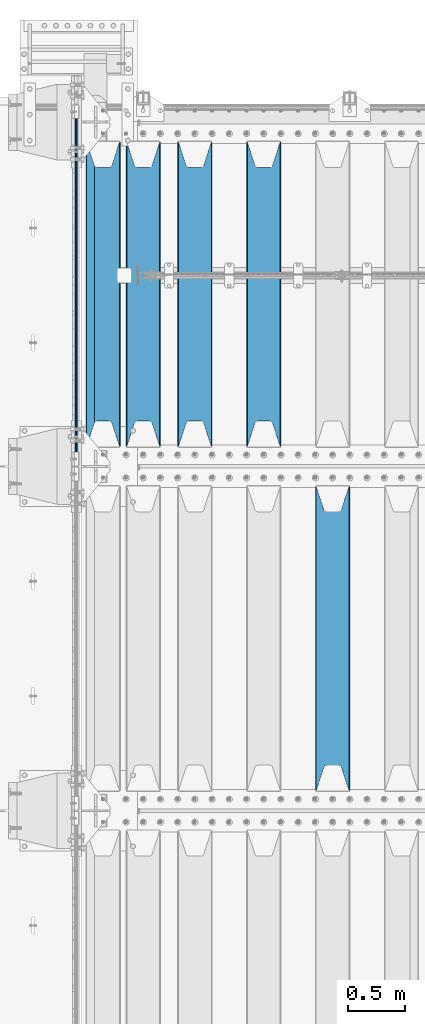
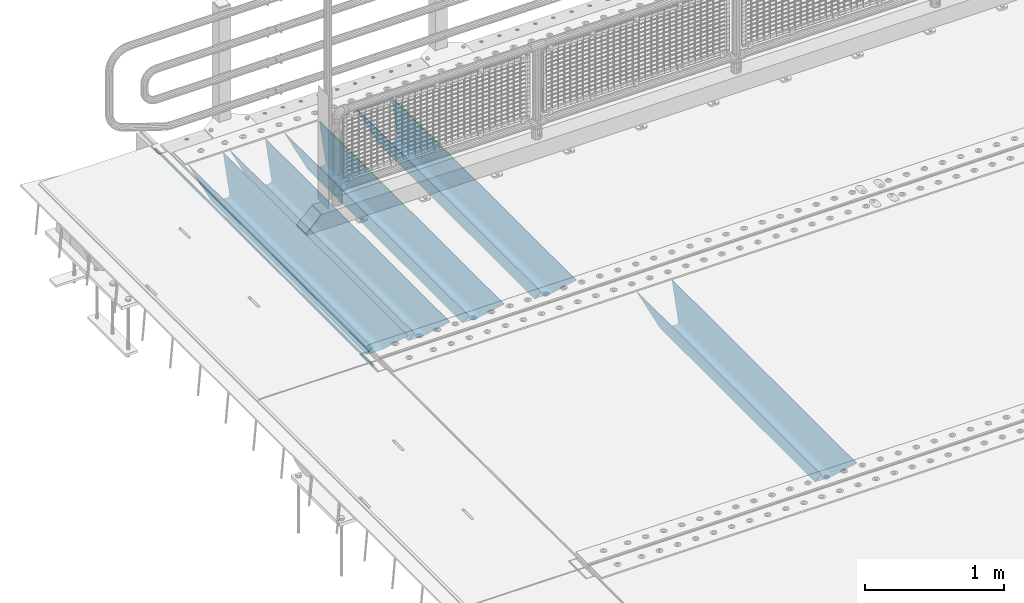
# One storey, part 113 of 240: 6 beams.
"""IFC2X3 building model written with IfcOpenShell, lengths in millimetres."""

import ifcopenshell
import ifcopenshell.guid

model = None  # the IFC model being written
_history = None  # IfcOwnerHistory: only IFC2X3 demands one
_inside = {}  # id of a spatial element -> (the spatial element, [elements in it])
_under = {}  # id of a project, library or spatial element -> (it, [spatial elements below it])
_declared = {}  # id of a project -> (the project, [libraries it declares])
_typed = {}  # id of a type object -> (the type object, [elements of that type])
_made_of = {}  # id of a material, layer set ... -> (it, [elements and type objects made of it])


def new_model(schema):
    """Start an empty IFC model of exactly this schema.

    Asked for "IFC4X3", IfcOpenShell would pick the latest addendum, in which some entities
    have other attributes; the version numbers below select the first issue.
    IFC2X3 requires an IfcOwnerHistory on every rooted entity: one is made here for all.
    """
    global model, _history
    if schema == "IFC4X3":
        model = ifcopenshell.file(schema_version=(4, 3, 0, 0))
    else:
        model = ifcopenshell.file(schema=schema)
    _inside.clear()
    _under.clear()
    _declared.clear()
    _typed.clear()
    _made_of.clear()
    _history = None
    if model.schema == "IFC2X3":
        org = make("IfcOrganization", Name="unknown")
        user = make(
            "IfcPersonAndOrganization",
            ThePerson=make("IfcPerson", FamilyName="unknown"),
            TheOrganization=org,
        )
        app = make(
            "IfcApplication",
            ApplicationDeveloper=org,
            Version="unknown",
            ApplicationFullName="unknown",
            ApplicationIdentifier="unknown",
        )
        _history = make(
            "IfcOwnerHistory",
            OwningUser=user,
            OwningApplication=app,
            ChangeAction="ADDED",
            CreationDate=0,
        )
    return model


def make(cls, **values):
    """One entity of the class cls with the attributes given. An attribute that is None is left unset."""
    return model.create_entity(
        cls, **{name: value for name, value in values.items() if value is not None}
    )


def rooted(cls, **values):
    """An entity with a GlobalId (a new one), such as an element, a storey or a relation."""
    return make(cls, GlobalId=ifcopenshell.guid.new(), OwnerHistory=_history, **values)


def si_unit(unit_type, name, prefix=None):
    """IfcSIUnit, for example si_unit("LENGTHUNIT", "METRE", prefix="MILLI")."""
    return make("IfcSIUnit", UnitType=unit_type, Prefix=prefix, Name=name)


def assignment(units):
    """IfcUnitAssignment: the units of a project."""
    return None if units is None else make("IfcUnitAssignment", Units=units)


def point(xyz):
    """IfcCartesianPoint."""
    return None if xyz is None else make("IfcCartesianPoint", Coordinates=xyz)


def direction(xyz):
    """IfcDirection."""
    return None if xyz is None else make("IfcDirection", DirectionRatios=xyz)


def frame(location, z_axis=None, x_axis=None):
    """IfcAxis2Placement3D, a coordinate frame: its origin and axes. An axis left out is left unset."""
    return make(
        "IfcAxis2Placement3D",
        Location=point(location),
        Axis=direction(z_axis),
        RefDirection=direction(x_axis),
    )


def origin_with_axes():
    """The frame at (0, 0, 0) with the z axis (0, 0, 1) and the x axis (1, 0, 0) written out."""
    return frame((0.0, 0.0, 0.0), z_axis=(0.0, 0.0, 1.0), x_axis=(1.0, 0.0, 0.0))


def place(relative_to, where):
    """IfcLocalPlacement: puts the frame where relative to a parent placement (None: the world)."""
    return make(
        "IfcLocalPlacement", PlacementRelTo=relative_to, RelativePlacement=where
    )


def context(
    kind, dimensions, precision=None, world=None, true_north=None, identifier=None
):
    """IfcGeometricRepresentationContext, for example the 3D "Model" context."""
    return make(
        "IfcGeometricRepresentationContext",
        ContextIdentifier=identifier,
        ContextType=kind,
        CoordinateSpaceDimension=dimensions,
        Precision=precision,
        WorldCoordinateSystem=world,
        TrueNorth=true_north,
    )


def subcontext(parent, identifier, kind, view, scale=None):
    """IfcGeometricRepresentationSubContext, for example "Body" below "Model"."""
    return make(
        "IfcGeometricRepresentationSubContext",
        ContextIdentifier=identifier,
        ContextType=kind,
        ParentContext=parent,
        TargetScale=scale,
        TargetView=view,
    )


def project(units=None, contexts=None):
    """IfcProject with its units and contexts."""
    return rooted(
        "IfcProject",
        Name="project",
        RepresentationContexts=contexts,
        UnitsInContext=assignment(units),
    )


def spatial(cls, under=None, at=None, **own):
    """A site, building, storey or space (cls), placed at a placement, below another one or the project."""
    s = rooted(cls, ObjectPlacement=at, **own)
    if under is not None:
        _under.setdefault(under.id(), (under, []))[1].append(s)
    return s


def faces_of(points, faces, orient=None, outer=None):
    """IfcFace entities. A face is a list of loops; a loop is a list of indices into points, from 0.

    orient and outer hold one flag for each loop. By default every Orientation is true, the
    first loop of a face is its IfcFaceOuterBound and the others are IfcFaceBound.
    """
    made = []
    for i, loops in enumerate(faces):
        bounds = []
        for j, loop in enumerate(loops):
            is_outer = j == 0 if outer is None else outer[i][j]
            bounds.append(
                make(
                    "IfcFaceOuterBound" if is_outer else "IfcFaceBound",
                    Bound=make("IfcPolyLoop", Polygon=[points[k] for k in loop]),
                    Orientation=True if orient is None else orient[i][j],
                )
            )
        made.append(make("IfcFace", Bounds=bounds))
    return made


def faceted_brep(points, faces, orient=None, outer=None, voids=None):
    """IfcFacetedBrep: a solid bounded by flat faces; with voids (closed shells), ...WithVoids."""
    shared = [point(p) for p in points]
    hull = make("IfcClosedShell", CfsFaces=faces_of(shared, faces, orient, outer))
    if voids is None:
        return make("IfcFacetedBrep", Outer=hull)
    return make(
        "IfcFacetedBrepWithVoids",
        Outer=hull,
        Voids=[
            make(cls, CfsFaces=faces_of(shared, fs, o, b)) for cls, fs, o, b in voids
        ],
    )


def shape(context_of_items, identifier, shape_type, items):
    """IfcShapeRepresentation: the items that make up one representation, for example the "Body"."""
    return make(
        "IfcShapeRepresentation",
        ContextOfItems=context_of_items,
        RepresentationIdentifier=identifier,
        RepresentationType=shape_type,
        Items=items,
    )


def material(Name=None, Category=None):
    """IfcMaterial."""
    return make("IfcMaterial", Name=Name, Category=Category)


def made_of(thing, what):
    """Note that an element or type object is made of a material, layer set ...; save() writes the relation."""
    if what is not None:
        _made_of.setdefault(what.id(), (what, []))[1].append(thing)
    return thing


def type_object(cls, material=None, **own):
    """A type object (cls), such as IfcWallType, which elements share."""
    return made_of(rooted(cls, **own), material)


def element(
    cls,
    number,
    at=None,
    inside=None,
    cuts=None,
    type_object=None,
    material=None,
    context=None,
    identifier="Body",
    shape_type=None,
    held_by="IfcProductDefinitionShape",
    body=None,
    shapes=None,
    **own,
):
    """One element of the class cls, such as IfcWall. Its Tag is "e" and its number.

    at: its placement. inside: the storey or other place that contains it. cuts: it is an
    opening in that element (IfcRelVoidsElement). A single representation is given by context,
    identifier, shape_type and body (its items); several are given by shapes. held_by: the class
    of the entity that holds the representations. save() writes the other relations.
    """
    e = rooted(cls, Tag="e%d" % number, ObjectPlacement=at, **own)
    if body is not None:
        shapes = [shape(context, identifier, shape_type, body)]
    if shapes is not None:
        e.Representation = make(held_by, Representations=shapes)
    if inside is not None:
        _inside.setdefault(inside.id(), (inside, []))[1].append(e)
    if cuts is not None:
        rooted(
            "IfcRelVoidsElement", RelatingBuildingElement=cuts, RelatedOpeningElement=e
        )
    if type_object is not None:
        _typed.setdefault(type_object.id(), (type_object, []))[1].append(e)
    return made_of(e, material)


def aggregate(whole, parts):
    """IfcRelAggregates: a whole, such as a stair, and the parts it consists of."""
    return rooted("IfcRelAggregates", RelatingObject=whole, RelatedObjects=parts)


def save(model, path):
    """Write the relations noted so far, then the file.

    IfcRelAggregates (storeys below a building ...), IfcRelContainedInSpatialStructure (elements
    in a storey), IfcRelDefinesByType, IfcRelAssociatesMaterial and IfcRelDeclares: one each for
    every whole, place, type object, material and project.
    """
    for whole, parts in _under.values():
        aggregate(whole, parts)
    for where, things in _inside.values():
        rooted(
            "IfcRelContainedInSpatialStructure",
            RelatedElements=things,
            RelatingStructure=where,
        )
    for kind, things in _typed.values():
        rooted("IfcRelDefinesByType", RelatedObjects=things, RelatingType=kind)
    for what, things in _made_of.values():
        rooted("IfcRelAssociatesMaterial", RelatedObjects=things, RelatingMaterial=what)
    for by, libraries in _declared.values():
        rooted("IfcRelDeclares", RelatingContext=by, RelatedDefinitions=libraries)
    model.write(path)


model = new_model("IFC2X3")

# Units and contexts
model_context = context("Model", 3, precision=1e-05, world=origin_with_axes())
body_context = subcontext(model_context, "Body", "Model", "MODEL_VIEW")
ifc_project = project(units=[si_unit("LENGTHUNIT", "METRE", prefix="MILLI"), si_unit("AREAUNIT", "SQUARE_METRE"), si_unit("VOLUMEUNIT", "CUBIC_METRE"), si_unit("MASSUNIT", "GRAM", prefix="KILO"), si_unit("TIMEUNIT", "SECOND"), si_unit("PLANEANGLEUNIT", "RADIAN"), si_unit("SOLIDANGLEUNIT", "STERADIAN"), si_unit("THERMODYNAMICTEMPERATUREUNIT", "DEGREE_CELSIUS"), si_unit("LUMINOUSINTENSITYUNIT", "LUMEN")], contexts=[model_context])

# Site, building, storey
site_placement = place(None, origin_with_axes())
site = spatial("IfcSite", under=ifc_project, at=site_placement, CompositionType="ELEMENT")
building_placement = place(site_placement, origin_with_axes())
building = spatial("IfcBuilding", under=site, at=building_placement, Name="Standard", CompositionType="ELEMENT")
storey_placement = place(building_placement, origin_with_axes())
storey = spatial("IfcBuildingStorey", under=building, at=storey_placement, Name="Undefined", CompositionType="ELEMENT", Elevation=0.0)

# Beams
ifc_material = material(Name="STEEL/S355N")
beam_type_1 = type_object("IfcBeamType", Name="D20", PredefinedType="NOTDEFINED")
beam_1_placement = place(storey_placement, frame((42415.0, 33004.9999999999, -25.9999999971316), z_axis=(0.0, 0.0, 1.0), x_axis=(0.0, 1.0, 0.0)))
element("IfcBeam", 1, at=beam_1_placement, inside=storey, type_object=beam_type_1, material=ifc_material, ObjectType="D20", context=body_context, shape_type="Brep", body=[
    faceted_brep([(0.0, -10.0, 0.0), (0.0, -7.07106781186303, -7.07106781186548), (3144.99999999996, -7.07106781186303, -7.07106781186548), (3144.99999999996, -10.0, 0.0), (0.0, 0.0, -10.0), (3144.99999999996, 0.0, -10.0), (0.0, 7.07106781186303, -7.07106781186547), (3144.99999999996, 7.07106781186303, -7.07106781186547), (0.0, 10.0, 0.0), (3144.99999999996, 10.0, 0.0), (0.0, 7.07106781186303, 7.07106781186548), (3144.99999999996, 7.07106781186303, 7.07106781186548), (0.0, 0.0, 10.0), (3144.99999999996, 0.0, 10.0), (0.0, -7.07106781186303, 7.07106781186548), (3144.99999999996, -7.07106781186303, 7.07106781186548)], [[[0, 1, 2, 3]], [[1, 4, 5, 2]], [[4, 6, 7, 5]], [[6, 8, 9, 7]], [[8, 10, 11, 9]], [[10, 12, 13, 11]], [[12, 14, 15, 13]], [[14, 0, 3, 15]], [[5, 7, 9, 11, 13, 15, 3, 2]], [[14, 12, 10, 8, 6, 4, 1, 0]]]),
])
beam_type_2 = type_object("IfcBeamType", PredefinedType="NOTDEFINED")
beam_2_placement = place(storey_placement, frame((44650.0, 30175.0, -115.0), z_axis=(0.0, 0.0, 1.0), x_axis=(0.0, 1.0, 0.0)))
element("IfcBeam", 2, at=beam_2_placement, inside=storey, type_object=beam_type_2, material=ifc_material, context=body_context, shape_type="Brep", body=[
    faceted_brep([(0.0, 150.0, 115.0), (0.0, 143.690000000002, 115.0), (2650.00000000297, 143.690000000002, 115.0), (2650.00000000297, 150.0, 115.0), (2650.00000000297, 142.059565218406, 110.000000003094), (2650.00000000297, 148.369565218403, 110.000000003094), (2441.90079219209, -80.1103600731149, -98.0992078077845), (2437.7588105432, -77.5672621345584, -102.241189456673), (2434.06523489747, -74.4080125315522, -105.934765102404), (2430.9108609509, -70.7102721255724, -109.089139048974), (2428.37322971128, -66.5649389910031, -111.626770288588), (2426.51472138055, -62.0739139532889, -113.485278619323), (2425.38102192092, -57.3475956567636, -114.618978078955), (2424.99999999987, -52.5021667386536, -115.0), (2424.99999999987, 52.5021667386536, -115.0), (2425.38102192092, 57.3475956567636, -114.618978078955), (2426.51472138055, 62.0739139532889, -113.485278619323), (2428.37322971128, 66.5649389910031, -111.626770288588), (2430.9108609509, 70.7102721255724, -109.089139048974), (2434.06523489747, 74.4080125315522, -105.934765102404), (2437.7588105432, 77.5672621345584, -102.241189456673), (2441.90079219209, 80.1103600731149, -98.0992078077846), (2446.38936140512, 81.9747917625791, -93.6106385947584), (2448.2494850041, 76.2713538057287, -91.7505149957729), (2444.62967112263, 74.76777986261, -95.3703288772456), (2441.28936334127, 72.7168944282894, -98.710636658607), (2438.31067330439, 70.1691124903809, -101.689326695487), (2435.76682334748, 67.1870637758839, -104.233176652398), (2433.72034654134, 63.8440531834931, -106.279653458539), (2432.22154950042, 60.2222587982324, -107.778450499454), (2431.30727574265, 56.4107117849126, -108.692724257221), (2430.99999999987, 52.5031078186876, -109.0), (2430.99999999987, -52.5031078186876, -109.0), (2431.30727574265, -56.4107117849126, -108.692724257221), (2432.22154950042, -60.2222587982324, -107.778450499454), (2433.72034654134, -63.8440531834931, -106.279653458539), (2435.76682334748, -67.1870637758839, -104.233176652398), (2438.31067330439, -70.1691124903809, -101.689326695487), (2441.28936334127, -72.7168944282894, -98.7106366586071), (2444.62967112263, -74.76777986261, -95.3703288772457), (2448.2494850041, -76.2713538057287, -91.7505149957729), (2650.00000000297, -142.059565218406, 110.000000003094), (2650.00000000297, -148.369565218403, 110.000000003094), (2446.38936140512, -81.9747917625791, -93.6106385947584), (2650.00000000297, -143.690000000002, 115.0), (2650.00000000297, -150.0, 115.0), (0.0, -143.690000000002, 115.0), (0.0, -150.0, 115.0), (0.0, -148.369565218258, 110.000000002667), (203.610638597427, -81.9747917625791, -93.6106385947584), (208.09920781045, -80.1103600731149, -98.0992078077845), (212.241189459342, -77.5672621345584, -102.241189456673), (215.93476510507, -74.4080125315522, -105.934765102404), (219.089139051641, -70.7102721255724, -109.089139048974), (221.626770291256, -66.5649389910031, -111.626770288588), (223.485278621989, -62.0739139532889, -113.485278619323), (224.618978081624, -57.3475956567636, -114.618978078955), (225.000000002663, -52.5021667386536, -115.0), (225.000000002663, 52.5021667386536, -115.0), (224.618978081624, 57.3475956567636, -114.618978078955), (223.485278621989, 62.0739139532889, -113.485278619323), (221.626770291256, 66.5649389910031, -111.626770288588), (219.089139051641, 70.7102721255724, -109.089139048974), (215.93476510507, 74.4080125315522, -105.934765102404), (212.241189459342, 77.5672621345584, -102.241189456673), (208.09920781045, 80.1103600731149, -98.0992078077846), (203.610638597427, 81.9747917625791, -93.6106385947584), (0.0, 148.369565218258, 110.000000002667), (0.0, 142.05956521826, 110.000000002667), (201.750514998439, 76.2713538057287, -91.7505149957729), (205.370328879908, 74.76777986261, -95.3703288772456), (208.710636661275, 72.7168944282894, -98.710636658607), (211.689326698153, 70.1691124903809, -101.689326695487), (214.233176655063, 67.1870637758839, -104.233176652398), (216.279653461206, 63.8440531834931, -106.279653458539), (217.778450502123, 60.2222587982324, -107.778450499454), (218.692724259887, 56.4107117849126, -108.692724257221), (219.000000002667, 52.5031078186876, -109.0), (219.000000002667, -52.5031078186876, -109.0), (218.692724259887, -56.4107117849126, -108.692724257221), (217.778450502123, -60.2222587982324, -107.778450499454), (216.279653461206, -63.8440531834931, -106.279653458539), (214.233176655063, -67.1870637758839, -104.233176652398), (211.689326698153, -70.1691124903809, -101.689326695487), (208.710636661275, -72.7168944282894, -98.7106366586071), (205.370328879915, -74.76777986261, -95.3703288772457), (201.750514998439, -76.2713538057287, -91.7505149957729), (0.0, -142.05956521826, 110.000000002667)], [[[0, 1, 2, 3]], [[3, 2, 4, 5]], [[6, 7, 8, 9, 10, 11, 12, 13, 14, 15, 16, 17, 18, 19, 20, 21, 22, 5, 4, 23, 24, 25, 26, 27, 28, 29, 30, 31, 32, 33, 34, 35, 36, 37, 38, 39, 40, 41, 42, 43]], [[44, 45, 42, 41]], [[46, 47, 45, 44]], [[43, 42, 45, 47, 48, 49]], [[6, 43, 49, 50]], [[7, 6, 50, 51]], [[8, 7, 51, 52]], [[9, 8, 52, 53]], [[10, 9, 53, 54]], [[11, 10, 54, 55]], [[12, 11, 55, 56]], [[13, 12, 56, 57]], [[14, 13, 57, 58]], [[15, 14, 58, 59]], [[16, 15, 59, 60]], [[17, 16, 60, 61]], [[18, 17, 61, 62]], [[19, 18, 62, 63]], [[20, 19, 63, 64]], [[21, 20, 64, 65]], [[22, 21, 65, 66]], [[0, 3, 5, 22, 66, 67]], [[1, 0, 67, 68]], [[23, 4, 2, 1, 68, 69]], [[24, 23, 69, 70]], [[25, 24, 70, 71]], [[26, 25, 71, 72]], [[27, 26, 72, 73]], [[28, 27, 73, 74]], [[29, 28, 74, 75]], [[30, 29, 75, 76]], [[31, 30, 76, 77]], [[32, 31, 77, 78]], [[33, 32, 78, 79]], [[34, 33, 79, 80]], [[35, 34, 80, 81]], [[36, 35, 81, 82]], [[37, 36, 82, 83]], [[38, 37, 83, 84]], [[39, 38, 84, 85]], [[40, 39, 85, 86]], [[46, 44, 41, 40, 86, 87]], [[47, 46, 87, 48]], [[86, 85, 84, 83, 82, 81, 80, 79, 78, 77, 76, 75, 74, 73, 72, 71, 70, 69, 68, 67, 66, 65, 64, 63, 62, 61, 60, 59, 58, 57, 56, 55, 54, 53, 52, 51, 50, 49, 48, 87]]]),
])
beam_3_placement = place(storey_placement, frame((44050.0, 33175.0, -115.0), z_axis=(0.0, 0.0, 1.0), x_axis=(0.0, 1.0, 0.0)))
element("IfcBeam", 3, at=beam_3_placement, inside=storey, type_object=beam_type_2, material=ifc_material, context=body_context, shape_type="Brep", body=[
    faceted_brep([(0.0, 150.0, 115.0), (0.0, 143.690000000002, 115.0), (2650.00000000297, 143.690000000002, 115.0), (2650.00000000297, 150.0, 115.0), (2650.00000000297, 142.059565218406, 110.000000003094), (2650.00000000297, 148.369565218403, 110.000000003094), (2441.90079219209, -80.1103600731149, -98.0992078077845), (2437.7588105432, -77.5672621345584, -102.241189456673), (2434.06523489747, -74.4080125315522, -105.934765102404), (2430.9108609509, -70.7102721255724, -109.089139048974), (2428.37322971128, -66.5649389910031, -111.626770288588), (2426.51472138055, -62.0739139532889, -113.485278619323), (2425.38102192092, -57.3475956567636, -114.618978078955), (2424.99999999987, -52.5021667386536, -115.0), (2424.99999999987, 52.5021667386536, -115.0), (2425.38102192092, 57.3475956567636, -114.618978078955), (2426.51472138055, 62.0739139532889, -113.485278619323), (2428.37322971128, 66.5649389910031, -111.626770288588), (2430.9108609509, 70.7102721255724, -109.089139048974), (2434.06523489747, 74.4080125315522, -105.934765102404), (2437.7588105432, 77.5672621345584, -102.241189456673), (2441.90079219209, 80.1103600731149, -98.0992078077846), (2446.38936140512, 81.9747917625791, -93.6106385947584), (2448.2494850041, 76.2713538057287, -91.7505149957729), (2444.62967112263, 74.76777986261, -95.3703288772456), (2441.28936334127, 72.7168944282894, -98.710636658607), (2438.31067330439, 70.1691124903809, -101.689326695487), (2435.76682334748, 67.1870637758839, -104.233176652398), (2433.72034654134, 63.8440531834931, -106.279653458539), (2432.22154950042, 60.2222587982324, -107.778450499454), (2431.30727574265, 56.4107117849126, -108.692724257221), (2430.99999999987, 52.5031078186876, -109.0), (2430.99999999987, -52.5031078186876, -109.0), (2431.30727574265, -56.4107117849126, -108.692724257221), (2432.22154950042, -60.2222587982324, -107.778450499454), (2433.72034654134, -63.8440531834931, -106.279653458539), (2435.76682334748, -67.1870637758839, -104.233176652398), (2438.31067330439, -70.1691124903809, -101.689326695487), (2441.28936334127, -72.7168944282894, -98.7106366586071), (2444.62967112263, -74.76777986261, -95.3703288772457), (2448.2494850041, -76.2713538057287, -91.7505149957729), (2650.00000000297, -142.059565218406, 110.000000003094), (2650.00000000297, -148.369565218403, 110.000000003094), (2446.38936140512, -81.9747917625791, -93.6106385947584), (2650.00000000297, -143.690000000002, 115.0), (2650.00000000297, -150.0, 115.0), (0.0, -143.690000000002, 115.0), (0.0, -150.0, 115.0), (0.0, -148.369565218258, 110.000000002667), (203.610638597427, -81.9747917625791, -93.6106385947584), (208.09920781045, -80.1103600731149, -98.0992078077845), (212.241189459342, -77.5672621345584, -102.241189456673), (215.93476510507, -74.4080125315522, -105.934765102404), (219.089139051641, -70.7102721255724, -109.089139048974), (221.626770291256, -66.5649389910031, -111.626770288588), (223.485278621989, -62.0739139532889, -113.485278619323), (224.618978081624, -57.3475956567636, -114.618978078955), (225.000000002663, -52.5021667386536, -115.0), (225.000000002663, 52.5021667386536, -115.0), (224.618978081624, 57.3475956567636, -114.618978078955), (223.485278621989, 62.0739139532889, -113.485278619323), (221.626770291256, 66.5649389910031, -111.626770288588), (219.089139051641, 70.7102721255724, -109.089139048974), (215.93476510507, 74.4080125315522, -105.934765102404), (212.241189459342, 77.5672621345584, -102.241189456673), (208.09920781045, 80.1103600731149, -98.0992078077846), (203.610638597427, 81.9747917625791, -93.6106385947584), (0.0, 148.369565218258, 110.000000002667), (0.0, 142.05956521826, 110.000000002667), (201.750514998439, 76.2713538057287, -91.7505149957729), (205.370328879908, 74.76777986261, -95.3703288772456), (208.710636661275, 72.7168944282894, -98.710636658607), (211.689326698153, 70.1691124903809, -101.689326695487), (214.233176655063, 67.1870637758839, -104.233176652398), (216.279653461206, 63.8440531834931, -106.279653458539), (217.778450502123, 60.2222587982324, -107.778450499454), (218.692724259887, 56.4107117849126, -108.692724257221), (219.000000002667, 52.5031078186876, -109.0), (219.000000002667, -52.5031078186876, -109.0), (218.692724259887, -56.4107117849126, -108.692724257221), (217.778450502123, -60.2222587982324, -107.778450499454), (216.279653461206, -63.8440531834931, -106.279653458539), (214.233176655063, -67.1870637758839, -104.233176652398), (211.689326698153, -70.1691124903809, -101.689326695487), (208.710636661275, -72.7168944282894, -98.7106366586071), (205.370328879915, -74.76777986261, -95.3703288772457), (201.750514998439, -76.2713538057287, -91.7505149957729), (0.0, -142.05956521826, 110.000000002667)], [[[0, 1, 2, 3]], [[3, 2, 4, 5]], [[6, 7, 8, 9, 10, 11, 12, 13, 14, 15, 16, 17, 18, 19, 20, 21, 22, 5, 4, 23, 24, 25, 26, 27, 28, 29, 30, 31, 32, 33, 34, 35, 36, 37, 38, 39, 40, 41, 42, 43]], [[44, 45, 42, 41]], [[46, 47, 45, 44]], [[43, 42, 45, 47, 48, 49]], [[6, 43, 49, 50]], [[7, 6, 50, 51]], [[8, 7, 51, 52]], [[9, 8, 52, 53]], [[10, 9, 53, 54]], [[11, 10, 54, 55]], [[12, 11, 55, 56]], [[13, 12, 56, 57]], [[14, 13, 57, 58]], [[15, 14, 58, 59]], [[16, 15, 59, 60]], [[17, 16, 60, 61]], [[18, 17, 61, 62]], [[19, 18, 62, 63]], [[20, 19, 63, 64]], [[21, 20, 64, 65]], [[22, 21, 65, 66]], [[0, 3, 5, 22, 66, 67]], [[1, 0, 67, 68]], [[23, 4, 2, 1, 68, 69]], [[24, 23, 69, 70]], [[25, 24, 70, 71]], [[26, 25, 71, 72]], [[27, 26, 72, 73]], [[28, 27, 73, 74]], [[29, 28, 74, 75]], [[30, 29, 75, 76]], [[31, 30, 76, 77]], [[32, 31, 77, 78]], [[33, 32, 78, 79]], [[34, 33, 79, 80]], [[35, 34, 80, 81]], [[36, 35, 81, 82]], [[37, 36, 82, 83]], [[38, 37, 83, 84]], [[39, 38, 84, 85]], [[40, 39, 85, 86]], [[46, 44, 41, 40, 86, 87]], [[47, 46, 87, 48]], [[86, 85, 84, 83, 82, 81, 80, 79, 78, 77, 76, 75, 74, 73, 72, 71, 70, 69, 68, 67, 66, 65, 64, 63, 62, 61, 60, 59, 58, 57, 56, 55, 54, 53, 52, 51, 50, 49, 48, 87]]]),
])
beam_4_placement = place(storey_placement, frame((43450.0, 33175.0, -115.0), z_axis=(0.0, 0.0, 1.0), x_axis=(0.0, 1.0, 0.0)))
element("IfcBeam", 4, at=beam_4_placement, inside=storey, type_object=beam_type_2, material=ifc_material, context=body_context, shape_type="Brep", body=[
    faceted_brep([(0.0, 150.0, 115.0), (0.0, 143.690000000002, 115.0), (2650.00000000297, 143.690000000002, 115.0), (2650.00000000297, 150.0, 115.0), (2650.00000000297, 142.059565218406, 110.000000003094), (2650.00000000297, 148.369565218403, 110.000000003094), (2441.90079219209, -80.1103600731149, -98.0992078077845), (2437.7588105432, -77.5672621345584, -102.241189456673), (2434.06523489747, -74.4080125315522, -105.934765102404), (2430.9108609509, -70.7102721255724, -109.089139048974), (2428.37322971128, -66.5649389910031, -111.626770288588), (2426.51472138055, -62.0739139532889, -113.485278619323), (2425.38102192092, -57.3475956567636, -114.618978078955), (2424.99999999987, -52.5021667386536, -115.0), (2424.99999999987, 52.5021667386536, -115.0), (2425.38102192092, 57.3475956567636, -114.618978078955), (2426.51472138055, 62.0739139532889, -113.485278619323), (2428.37322971128, 66.5649389910031, -111.626770288588), (2430.9108609509, 70.7102721255724, -109.089139048974), (2434.06523489747, 74.4080125315522, -105.934765102404), (2437.7588105432, 77.5672621345584, -102.241189456673), (2441.90079219209, 80.1103600731149, -98.0992078077846), (2446.38936140512, 81.9747917625791, -93.6106385947584), (2448.2494850041, 76.2713538057287, -91.7505149957729), (2444.62967112263, 74.76777986261, -95.3703288772456), (2441.28936334127, 72.7168944282894, -98.710636658607), (2438.31067330439, 70.1691124903809, -101.689326695487), (2435.76682334748, 67.1870637758839, -104.233176652398), (2433.72034654134, 63.8440531834931, -106.279653458539), (2432.22154950042, 60.2222587982324, -107.778450499454), (2431.30727574265, 56.4107117849126, -108.692724257221), (2430.99999999987, 52.5031078186876, -109.0), (2430.99999999987, -52.5031078186876, -109.0), (2431.30727574265, -56.4107117849126, -108.692724257221), (2432.22154950042, -60.2222587982324, -107.778450499454), (2433.72034654134, -63.8440531834931, -106.279653458539), (2435.76682334748, -67.1870637758839, -104.233176652398), (2438.31067330439, -70.1691124903809, -101.689326695487), (2441.28936334127, -72.7168944282894, -98.7106366586071), (2444.62967112263, -74.76777986261, -95.3703288772457), (2448.2494850041, -76.2713538057287, -91.7505149957729), (2650.00000000297, -142.059565218406, 110.000000003094), (2650.00000000297, -148.369565218403, 110.000000003094), (2446.38936140512, -81.9747917625791, -93.6106385947584), (2650.00000000297, -143.690000000002, 115.0), (2650.00000000297, -150.0, 115.0), (0.0, -143.690000000002, 115.0), (0.0, -150.0, 115.0), (0.0, -148.369565218258, 110.000000002667), (203.610638597427, -81.9747917625791, -93.6106385947584), (208.09920781045, -80.1103600731149, -98.0992078077845), (212.241189459342, -77.5672621345584, -102.241189456673), (215.93476510507, -74.4080125315522, -105.934765102404), (219.089139051641, -70.7102721255724, -109.089139048974), (221.626770291256, -66.5649389910031, -111.626770288588), (223.485278621989, -62.0739139532889, -113.485278619323), (224.618978081624, -57.3475956567636, -114.618978078955), (225.000000002663, -52.5021667386536, -115.0), (225.000000002663, 52.5021667386536, -115.0), (224.618978081624, 57.3475956567636, -114.618978078955), (223.485278621989, 62.0739139532889, -113.485278619323), (221.626770291256, 66.5649389910031, -111.626770288588), (219.089139051641, 70.7102721255724, -109.089139048974), (215.93476510507, 74.4080125315522, -105.934765102404), (212.241189459342, 77.5672621345584, -102.241189456673), (208.09920781045, 80.1103600731149, -98.0992078077846), (203.610638597427, 81.9747917625791, -93.6106385947584), (0.0, 148.369565218258, 110.000000002667), (0.0, 142.05956521826, 110.000000002667), (201.750514998439, 76.2713538057287, -91.7505149957729), (205.370328879908, 74.76777986261, -95.3703288772456), (208.710636661275, 72.7168944282894, -98.710636658607), (211.689326698153, 70.1691124903809, -101.689326695487), (214.233176655063, 67.1870637758839, -104.233176652398), (216.279653461206, 63.8440531834931, -106.279653458539), (217.778450502123, 60.2222587982324, -107.778450499454), (218.692724259887, 56.4107117849126, -108.692724257221), (219.000000002667, 52.5031078186876, -109.0), (219.000000002667, -52.5031078186876, -109.0), (218.692724259887, -56.4107117849126, -108.692724257221), (217.778450502123, -60.2222587982324, -107.778450499454), (216.279653461206, -63.8440531834931, -106.279653458539), (214.233176655063, -67.1870637758839, -104.233176652398), (211.689326698153, -70.1691124903809, -101.689326695487), (208.710636661275, -72.7168944282894, -98.7106366586071), (205.370328879915, -74.76777986261, -95.3703288772457), (201.750514998439, -76.2713538057287, -91.7505149957729), (0.0, -142.05956521826, 110.000000002667)], [[[0, 1, 2, 3]], [[3, 2, 4, 5]], [[6, 7, 8, 9, 10, 11, 12, 13, 14, 15, 16, 17, 18, 19, 20, 21, 22, 5, 4, 23, 24, 25, 26, 27, 28, 29, 30, 31, 32, 33, 34, 35, 36, 37, 38, 39, 40, 41, 42, 43]], [[44, 45, 42, 41]], [[46, 47, 45, 44]], [[43, 42, 45, 47, 48, 49]], [[6, 43, 49, 50]], [[7, 6, 50, 51]], [[8, 7, 51, 52]], [[9, 8, 52, 53]], [[10, 9, 53, 54]], [[11, 10, 54, 55]], [[12, 11, 55, 56]], [[13, 12, 56, 57]], [[14, 13, 57, 58]], [[15, 14, 58, 59]], [[16, 15, 59, 60]], [[17, 16, 60, 61]], [[18, 17, 61, 62]], [[19, 18, 62, 63]], [[20, 19, 63, 64]], [[21, 20, 64, 65]], [[22, 21, 65, 66]], [[0, 3, 5, 22, 66, 67]], [[1, 0, 67, 68]], [[23, 4, 2, 1, 68, 69]], [[24, 23, 69, 70]], [[25, 24, 70, 71]], [[26, 25, 71, 72]], [[27, 26, 72, 73]], [[28, 27, 73, 74]], [[29, 28, 74, 75]], [[30, 29, 75, 76]], [[31, 30, 76, 77]], [[32, 31, 77, 78]], [[33, 32, 78, 79]], [[34, 33, 79, 80]], [[35, 34, 80, 81]], [[36, 35, 81, 82]], [[37, 36, 82, 83]], [[38, 37, 83, 84]], [[39, 38, 84, 85]], [[40, 39, 85, 86]], [[46, 44, 41, 40, 86, 87]], [[47, 46, 87, 48]], [[86, 85, 84, 83, 82, 81, 80, 79, 78, 77, 76, 75, 74, 73, 72, 71, 70, 69, 68, 67, 66, 65, 64, 63, 62, 61, 60, 59, 58, 57, 56, 55, 54, 53, 52, 51, 50, 49, 48, 87]]]),
])
beam_5_placement = place(storey_placement, frame((43000.0, 33175.0, -115.0), z_axis=(0.0, 0.0, 1.0), x_axis=(0.0, 1.0, 0.0)))
element("IfcBeam", 5, at=beam_5_placement, inside=storey, type_object=beam_type_2, material=ifc_material, context=body_context, shape_type="Brep", body=[
    faceted_brep([(0.0, 150.0, 115.0), (0.0, 143.690000000002, 115.0), (2650.00000000297, 143.690000000002, 115.0), (2650.00000000297, 150.0, 115.0), (2650.00000000297, 142.059565218406, 110.000000003094), (2650.00000000297, 148.369565218403, 110.000000003094), (2441.90079219209, -80.1103600731149, -98.0992078077845), (2437.7588105432, -77.5672621345584, -102.241189456673), (2434.06523489747, -74.4080125315522, -105.934765102404), (2430.9108609509, -70.7102721255724, -109.089139048974), (2428.37322971128, -66.5649389910031, -111.626770288588), (2426.51472138055, -62.0739139532889, -113.485278619323), (2425.38102192092, -57.3475956567636, -114.618978078955), (2424.99999999987, -52.5021667386536, -115.0), (2424.99999999987, 52.5021667386536, -115.0), (2425.38102192092, 57.3475956567636, -114.618978078955), (2426.51472138055, 62.0739139532889, -113.485278619323), (2428.37322971128, 66.5649389910031, -111.626770288588), (2430.9108609509, 70.7102721255724, -109.089139048974), (2434.06523489747, 74.4080125315522, -105.934765102404), (2437.7588105432, 77.5672621345584, -102.241189456673), (2441.90079219209, 80.1103600731149, -98.0992078077846), (2446.38936140512, 81.9747917625791, -93.6106385947584), (2448.2494850041, 76.2713538057287, -91.7505149957729), (2444.62967112263, 74.76777986261, -95.3703288772456), (2441.28936334127, 72.7168944282894, -98.710636658607), (2438.31067330439, 70.1691124903809, -101.689326695487), (2435.76682334748, 67.1870637758839, -104.233176652398), (2433.72034654134, 63.8440531834931, -106.279653458539), (2432.22154950042, 60.2222587982324, -107.778450499454), (2431.30727574265, 56.4107117849126, -108.692724257221), (2430.99999999987, 52.5031078186876, -109.0), (2430.99999999987, -52.5031078186876, -109.0), (2431.30727574265, -56.4107117849126, -108.692724257221), (2432.22154950042, -60.2222587982324, -107.778450499454), (2433.72034654134, -63.8440531834931, -106.279653458539), (2435.76682334748, -67.1870637758839, -104.233176652398), (2438.31067330439, -70.1691124903809, -101.689326695487), (2441.28936334127, -72.7168944282894, -98.7106366586071), (2444.62967112263, -74.76777986261, -95.3703288772457), (2448.2494850041, -76.2713538057287, -91.7505149957729), (2650.00000000297, -142.059565218406, 110.000000003094), (2650.00000000297, -148.369565218403, 110.000000003094), (2446.38936140512, -81.9747917625791, -93.6106385947584), (2650.00000000297, -143.690000000002, 115.0), (2650.00000000297, -150.0, 115.0), (0.0, -143.690000000002, 115.0), (0.0, -150.0, 115.0), (0.0, -148.369565218258, 110.000000002667), (203.610638597427, -81.9747917625791, -93.6106385947584), (208.09920781045, -80.1103600731149, -98.0992078077845), (212.241189459342, -77.5672621345584, -102.241189456673), (215.93476510507, -74.4080125315522, -105.934765102404), (219.089139051641, -70.7102721255724, -109.089139048974), (221.626770291256, -66.5649389910031, -111.626770288588), (223.485278621989, -62.0739139532889, -113.485278619323), (224.618978081624, -57.3475956567636, -114.618978078955), (225.000000002663, -52.5021667386536, -115.0), (225.000000002663, 52.5021667386536, -115.0), (224.618978081624, 57.3475956567636, -114.618978078955), (223.485278621989, 62.0739139532889, -113.485278619323), (221.626770291256, 66.5649389910031, -111.626770288588), (219.089139051641, 70.7102721255724, -109.089139048974), (215.93476510507, 74.4080125315522, -105.934765102404), (212.241189459342, 77.5672621345584, -102.241189456673), (208.09920781045, 80.1103600731149, -98.0992078077846), (203.610638597427, 81.9747917625791, -93.6106385947584), (0.0, 148.369565218258, 110.000000002667), (0.0, 142.05956521826, 110.000000002667), (201.750514998439, 76.2713538057287, -91.7505149957729), (205.370328879908, 74.76777986261, -95.3703288772456), (208.710636661275, 72.7168944282894, -98.710636658607), (211.689326698153, 70.1691124903809, -101.689326695487), (214.233176655063, 67.1870637758839, -104.233176652398), (216.279653461206, 63.8440531834931, -106.279653458539), (217.778450502123, 60.2222587982324, -107.778450499454), (218.692724259887, 56.4107117849126, -108.692724257221), (219.000000002667, 52.5031078186876, -109.0), (219.000000002667, -52.5031078186876, -109.0), (218.692724259887, -56.4107117849126, -108.692724257221), (217.778450502123, -60.2222587982324, -107.778450499454), (216.279653461206, -63.8440531834931, -106.279653458539), (214.233176655063, -67.1870637758839, -104.233176652398), (211.689326698153, -70.1691124903809, -101.689326695487), (208.710636661275, -72.7168944282894, -98.7106366586071), (205.370328879915, -74.76777986261, -95.3703288772457), (201.750514998439, -76.2713538057287, -91.7505149957729), (0.0, -142.05956521826, 110.000000002667)], [[[0, 1, 2, 3]], [[3, 2, 4, 5]], [[6, 7, 8, 9, 10, 11, 12, 13, 14, 15, 16, 17, 18, 19, 20, 21, 22, 5, 4, 23, 24, 25, 26, 27, 28, 29, 30, 31, 32, 33, 34, 35, 36, 37, 38, 39, 40, 41, 42, 43]], [[44, 45, 42, 41]], [[46, 47, 45, 44]], [[43, 42, 45, 47, 48, 49]], [[6, 43, 49, 50]], [[7, 6, 50, 51]], [[8, 7, 51, 52]], [[9, 8, 52, 53]], [[10, 9, 53, 54]], [[11, 10, 54, 55]], [[12, 11, 55, 56]], [[13, 12, 56, 57]], [[14, 13, 57, 58]], [[15, 14, 58, 59]], [[16, 15, 59, 60]], [[17, 16, 60, 61]], [[18, 17, 61, 62]], [[19, 18, 62, 63]], [[20, 19, 63, 64]], [[21, 20, 64, 65]], [[22, 21, 65, 66]], [[0, 3, 5, 22, 66, 67]], [[1, 0, 67, 68]], [[23, 4, 2, 1, 68, 69]], [[24, 23, 69, 70]], [[25, 24, 70, 71]], [[26, 25, 71, 72]], [[27, 26, 72, 73]], [[28, 27, 73, 74]], [[29, 28, 74, 75]], [[30, 29, 75, 76]], [[31, 30, 76, 77]], [[32, 31, 77, 78]], [[33, 32, 78, 79]], [[34, 33, 79, 80]], [[35, 34, 80, 81]], [[36, 35, 81, 82]], [[37, 36, 82, 83]], [[38, 37, 83, 84]], [[39, 38, 84, 85]], [[40, 39, 85, 86]], [[46, 44, 41, 40, 86, 87]], [[47, 46, 87, 48]], [[86, 85, 84, 83, 82, 81, 80, 79, 78, 77, 76, 75, 74, 73, 72, 71, 70, 69, 68, 67, 66, 65, 64, 63, 62, 61, 60, 59, 58, 57, 56, 55, 54, 53, 52, 51, 50, 49, 48, 87]]]),
])
beam_6_placement = place(storey_placement, frame((42650.0, 33175.0, -115.0), z_axis=(0.0, 0.0, 1.0), x_axis=(0.0, 1.0, 0.0)))
element("IfcBeam", 6, at=beam_6_placement, inside=storey, type_object=beam_type_2, material=ifc_material, context=body_context, shape_type="Brep", body=[
    faceted_brep([(0.0, 150.0, 115.0), (0.0, 143.690000000002, 115.0), (2650.00000000297, 143.690000000002, 115.0), (2650.00000000297, 150.0, 115.0), (2650.00000000297, 142.059565218406, 110.000000003094), (2650.00000000297, 148.369565218403, 110.000000003094), (2441.90079219209, -80.1103600731149, -98.0992078077845), (2437.7588105432, -77.5672621345584, -102.241189456673), (2434.06523489747, -74.4080125315522, -105.934765102404), (2430.9108609509, -70.7102721255724, -109.089139048974), (2428.37322971128, -66.5649389910031, -111.626770288588), (2426.51472138055, -62.0739139532889, -113.485278619323), (2425.38102192092, -57.3475956567636, -114.618978078955), (2424.99999999987, -52.5021667386536, -115.0), (2424.99999999987, 52.5021667386536, -115.0), (2425.38102192092, 57.3475956567636, -114.618978078955), (2426.51472138055, 62.0739139532889, -113.485278619323), (2428.37322971128, 66.5649389910031, -111.626770288588), (2430.9108609509, 70.7102721255724, -109.089139048974), (2434.06523489747, 74.4080125315522, -105.934765102404), (2437.7588105432, 77.5672621345584, -102.241189456673), (2441.90079219209, 80.1103600731149, -98.0992078077846), (2446.38936140512, 81.9747917625791, -93.6106385947584), (2448.2494850041, 76.2713538057287, -91.7505149957729), (2444.62967112263, 74.76777986261, -95.3703288772456), (2441.28936334127, 72.7168944282894, -98.710636658607), (2438.31067330439, 70.1691124903809, -101.689326695487), (2435.76682334748, 67.1870637758839, -104.233176652398), (2433.72034654134, 63.8440531834931, -106.279653458539), (2432.22154950042, 60.2222587982324, -107.778450499454), (2431.30727574265, 56.4107117849126, -108.692724257221), (2430.99999999987, 52.5031078186876, -109.0), (2430.99999999987, -52.5031078186876, -109.0), (2431.30727574265, -56.4107117849126, -108.692724257221), (2432.22154950042, -60.2222587982324, -107.778450499454), (2433.72034654134, -63.8440531834931, -106.279653458539), (2435.76682334748, -67.1870637758839, -104.233176652398), (2438.31067330439, -70.1691124903809, -101.689326695487), (2441.28936334127, -72.7168944282894, -98.7106366586071), (2444.62967112263, -74.76777986261, -95.3703288772457), (2448.2494850041, -76.2713538057287, -91.7505149957729), (2650.00000000297, -142.059565218406, 110.000000003094), (2650.00000000297, -148.369565218403, 110.000000003094), (2446.38936140512, -81.9747917625791, -93.6106385947584), (2650.00000000297, -143.690000000002, 115.0), (2650.00000000297, -150.0, 115.0), (0.0, -143.690000000002, 115.0), (0.0, -150.0, 115.0), (0.0, -148.369565218258, 110.000000002667), (203.610638597427, -81.9747917625791, -93.6106385947584), (208.09920781045, -80.1103600731149, -98.0992078077845), (212.241189459342, -77.5672621345584, -102.241189456673), (215.93476510507, -74.4080125315522, -105.934765102404), (219.089139051641, -70.7102721255724, -109.089139048974), (221.626770291256, -66.5649389910031, -111.626770288588), (223.485278621989, -62.0739139532889, -113.485278619323), (224.618978081624, -57.3475956567636, -114.618978078955), (225.000000002663, -52.5021667386536, -115.0), (225.000000002663, 52.5021667386536, -115.0), (224.618978081624, 57.3475956567636, -114.618978078955), (223.485278621989, 62.0739139532889, -113.485278619323), (221.626770291256, 66.5649389910031, -111.626770288588), (219.089139051641, 70.7102721255724, -109.089139048974), (215.93476510507, 74.4080125315522, -105.934765102404), (212.241189459342, 77.5672621345584, -102.241189456673), (208.09920781045, 80.1103600731149, -98.0992078077846), (203.610638597427, 81.9747917625791, -93.6106385947584), (0.0, 148.369565218258, 110.000000002667), (0.0, 142.05956521826, 110.000000002667), (201.750514998439, 76.2713538057287, -91.7505149957729), (205.370328879908, 74.76777986261, -95.3703288772456), (208.710636661275, 72.7168944282894, -98.710636658607), (211.689326698153, 70.1691124903809, -101.689326695487), (214.233176655063, 67.1870637758839, -104.233176652398), (216.279653461206, 63.8440531834931, -106.279653458539), (217.778450502123, 60.2222587982324, -107.778450499454), (218.692724259887, 56.4107117849126, -108.692724257221), (219.000000002667, 52.5031078186876, -109.0), (219.000000002667, -52.5031078186876, -109.0), (218.692724259887, -56.4107117849126, -108.692724257221), (217.778450502123, -60.2222587982324, -107.778450499454), (216.279653461206, -63.8440531834931, -106.279653458539), (214.233176655063, -67.1870637758839, -104.233176652398), (211.689326698153, -70.1691124903809, -101.689326695487), (208.710636661275, -72.7168944282894, -98.7106366586071), (205.370328879915, -74.76777986261, -95.3703288772457), (201.750514998439, -76.2713538057287, -91.7505149957729), (0.0, -142.05956521826, 110.000000002667)], [[[0, 1, 2, 3]], [[3, 2, 4, 5]], [[6, 7, 8, 9, 10, 11, 12, 13, 14, 15, 16, 17, 18, 19, 20, 21, 22, 5, 4, 23, 24, 25, 26, 27, 28, 29, 30, 31, 32, 33, 34, 35, 36, 37, 38, 39, 40, 41, 42, 43]], [[44, 45, 42, 41]], [[46, 47, 45, 44]], [[43, 42, 45, 47, 48, 49]], [[6, 43, 49, 50]], [[7, 6, 50, 51]], [[8, 7, 51, 52]], [[9, 8, 52, 53]], [[10, 9, 53, 54]], [[11, 10, 54, 55]], [[12, 11, 55, 56]], [[13, 12, 56, 57]], [[14, 13, 57, 58]], [[15, 14, 58, 59]], [[16, 15, 59, 60]], [[17, 16, 60, 61]], [[18, 17, 61, 62]], [[19, 18, 62, 63]], [[20, 19, 63, 64]], [[21, 20, 64, 65]], [[22, 21, 65, 66]], [[0, 3, 5, 22, 66, 67]], [[1, 0, 67, 68]], [[23, 4, 2, 1, 68, 69]], [[24, 23, 69, 70]], [[25, 24, 70, 71]], [[26, 25, 71, 72]], [[27, 26, 72, 73]], [[28, 27, 73, 74]], [[29, 28, 74, 75]], [[30, 29, 75, 76]], [[31, 30, 76, 77]], [[32, 31, 77, 78]], [[33, 32, 78, 79]], [[34, 33, 79, 80]], [[35, 34, 80, 81]], [[36, 35, 81, 82]], [[37, 36, 82, 83]], [[38, 37, 83, 84]], [[39, 38, 84, 85]], [[40, 39, 85, 86]], [[46, 44, 41, 40, 86, 87]], [[47, 46, 87, 48]], [[86, 85, 84, 83, 82, 81, 80, 79, 78, 77, 76, 75, 74, 73, 72, 71, 70, 69, 68, 67, 66, 65, 64, 63, 62, 61, 60, 59, 58, 57, 56, 55, 54, 53, 52, 51, 50, 49, 48, 87]]]),
])

save(model, "model.ifc")
